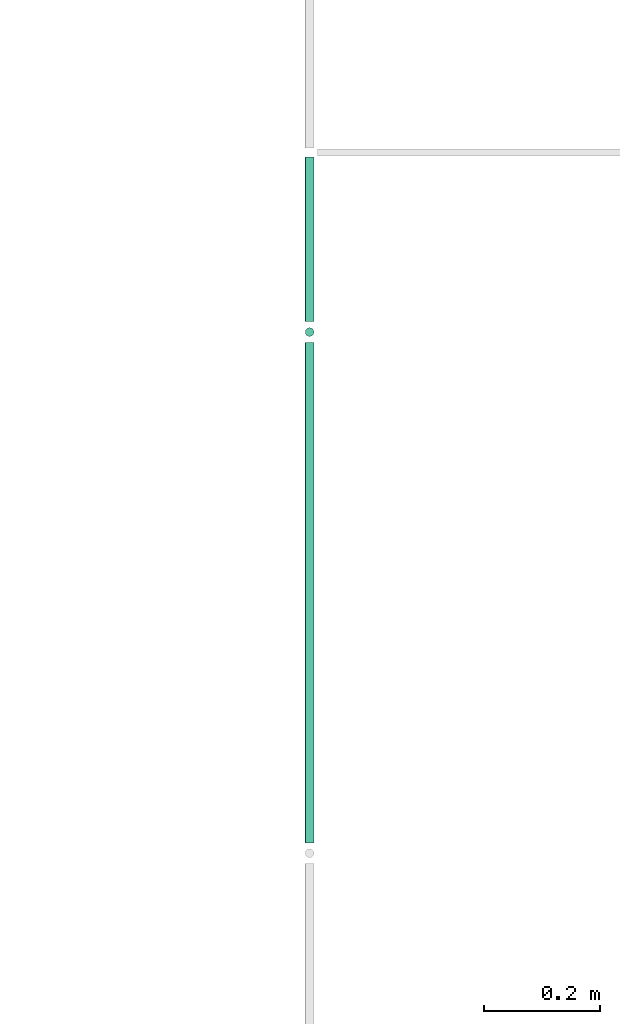
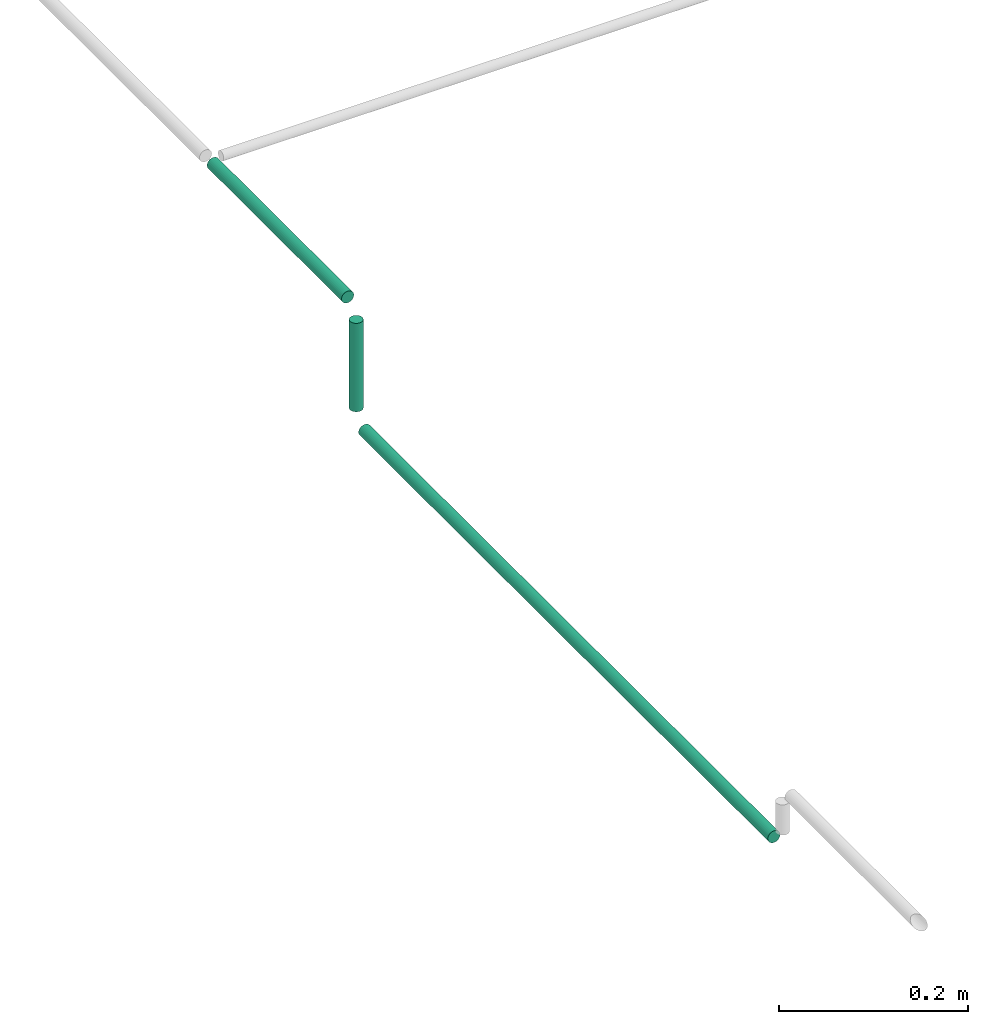
# One storey, part 43 of 65: 3 flow segments.
"""IFC2X3 building model written with IfcOpenShell, lengths in millimetres."""

import ifcopenshell
import ifcopenshell.guid

model = None  # the IFC model being written
_history = None  # IfcOwnerHistory: only IFC2X3 demands one
_inside = {}  # id of a spatial element -> (the spatial element, [elements in it])
_under = {}  # id of a project, library or spatial element -> (it, [spatial elements below it])
_declared = {}  # id of a project -> (the project, [libraries it declares])
_typed = {}  # id of a type object -> (the type object, [elements of that type])
_made_of = {}  # id of a material, layer set ... -> (it, [elements and type objects made of it])


def new_model(schema):
    """Start an empty IFC model of exactly this schema.

    Asked for "IFC4X3", IfcOpenShell would pick the latest addendum, in which some entities
    have other attributes; the version numbers below select the first issue.
    IFC2X3 requires an IfcOwnerHistory on every rooted entity: one is made here for all.
    """
    global model, _history
    if schema == "IFC4X3":
        model = ifcopenshell.file(schema_version=(4, 3, 0, 0))
    else:
        model = ifcopenshell.file(schema=schema)
    _inside.clear()
    _under.clear()
    _declared.clear()
    _typed.clear()
    _made_of.clear()
    _history = None
    if model.schema == "IFC2X3":
        org = make("IfcOrganization", Name="unknown")
        user = make(
            "IfcPersonAndOrganization",
            ThePerson=make("IfcPerson", FamilyName="unknown"),
            TheOrganization=org,
        )
        app = make(
            "IfcApplication",
            ApplicationDeveloper=org,
            Version="unknown",
            ApplicationFullName="unknown",
            ApplicationIdentifier="unknown",
        )
        _history = make(
            "IfcOwnerHistory",
            OwningUser=user,
            OwningApplication=app,
            ChangeAction="ADDED",
            CreationDate=0,
        )
    return model


def make(cls, **values):
    """One entity of the class cls with the attributes given. An attribute that is None is left unset."""
    return model.create_entity(
        cls, **{name: value for name, value in values.items() if value is not None}
    )


def entity(cls, *values):
    """Any entity or typed value of the class cls, its attributes in the order of the schema. None: left unset."""
    e = model.create_entity(cls)
    for i, value in enumerate(values):
        if value is not None:
            e[i] = value
    return e


def rooted(cls, **values):
    """An entity with a GlobalId (a new one), such as an element, a storey or a relation."""
    return make(cls, GlobalId=ifcopenshell.guid.new(), OwnerHistory=_history, **values)


def si_unit(unit_type, name, prefix=None):
    """IfcSIUnit, for example si_unit("LENGTHUNIT", "METRE", prefix="MILLI")."""
    return make("IfcSIUnit", UnitType=unit_type, Prefix=prefix, Name=name)


def converted_unit(unit_type, name, factor, base, dimensions=None, offset=None):
    """IfcConversionBasedUnit, such as the inch: factor (a typed value) times the base unit."""
    return make(
        "IfcConversionBasedUnit"
        if offset is None
        else "IfcConversionBasedUnitWithOffset",
        ConversionOffset=offset,
        Dimensions=None
        if dimensions is None
        else entity("IfcDimensionalExponents", *dimensions),
        UnitType=unit_type,
        Name=name,
        ConversionFactor=make(
            "IfcMeasureWithUnit", ValueComponent=factor, UnitComponent=base
        ),
    )


def derived_unit(unit_type, elements):
    """IfcDerivedUnit: a product of units, each with its exponent."""
    return make(
        "IfcDerivedUnit",
        Elements=[
            make("IfcDerivedUnitElement", Unit=unit, Exponent=power)
            for unit, power in elements
        ],
        UnitType=unit_type,
    )


def assignment(units):
    """IfcUnitAssignment: the units of a project."""
    return None if units is None else make("IfcUnitAssignment", Units=units)


def point(xyz):
    """IfcCartesianPoint."""
    return None if xyz is None else make("IfcCartesianPoint", Coordinates=xyz)


def direction(xyz):
    """IfcDirection."""
    return None if xyz is None else make("IfcDirection", DirectionRatios=xyz)


def frame(location, z_axis=None, x_axis=None):
    """IfcAxis2Placement3D, a coordinate frame: its origin and axes. An axis left out is left unset."""
    return make(
        "IfcAxis2Placement3D",
        Location=point(location),
        Axis=direction(z_axis),
        RefDirection=direction(x_axis),
    )


def frame_2d(location, x_axis=None):
    """IfcAxis2Placement2D, a coordinate frame in the plane: its origin and x axis."""
    return make(
        "IfcAxis2Placement2D", Location=point(location), RefDirection=direction(x_axis)
    )


def origin():
    """The frame at (0, 0, 0) with its axes left unset."""
    return frame((0.0, 0.0, 0.0))


def origin_2d_with_axis():
    """The frame at (0, 0) in the plane with the x axis (1, 0) written out."""
    return frame_2d((0.0, 0.0), x_axis=(1.0, 0.0))


def place(relative_to, where):
    """IfcLocalPlacement: puts the frame where relative to a parent placement (None: the world)."""
    return make(
        "IfcLocalPlacement", PlacementRelTo=relative_to, RelativePlacement=where
    )


def context(
    kind, dimensions, precision=None, world=None, true_north=None, identifier=None
):
    """IfcGeometricRepresentationContext, for example the 3D "Model" context."""
    return make(
        "IfcGeometricRepresentationContext",
        ContextIdentifier=identifier,
        ContextType=kind,
        CoordinateSpaceDimension=dimensions,
        Precision=precision,
        WorldCoordinateSystem=world,
        TrueNorth=true_north,
    )


def subcontext(parent, identifier, kind, view, scale=None):
    """IfcGeometricRepresentationSubContext, for example "Body" below "Model"."""
    return make(
        "IfcGeometricRepresentationSubContext",
        ContextIdentifier=identifier,
        ContextType=kind,
        ParentContext=parent,
        TargetScale=scale,
        TargetView=view,
    )


def project(units=None, contexts=None):
    """IfcProject with its units and contexts."""
    return rooted(
        "IfcProject",
        Name="project",
        RepresentationContexts=contexts,
        UnitsInContext=assignment(units),
    )


def spatial(cls, under=None, at=None, **own):
    """A site, building, storey or space (cls), placed at a placement, below another one or the project."""
    s = rooted(cls, ObjectPlacement=at, **own)
    if under is not None:
        _under.setdefault(under.id(), (under, []))[1].append(s)
    return s


def profile(cls, at=None, kind="AREA", **sizes):
    """A parametric profile (cls). Its sizes go by their IFC names, for example OverallWidth=200.0."""
    return make(cls, ProfileType=kind, Position=at, **sizes)


def circle(**sizes):
    """IfcCircleProfileDef."""
    return profile("IfcCircleProfileDef", **sizes)


def extrude(swept, where, along, depth):
    """IfcExtrudedAreaSolid: the profile swept, set in the frame where, extruded along a direction by depth."""
    return make(
        "IfcExtrudedAreaSolid",
        SweptArea=swept,
        Position=where,
        ExtrudedDirection=direction(along),
        Depth=depth,
    )


def shape(context_of_items, identifier, shape_type, items):
    """IfcShapeRepresentation: the items that make up one representation, for example the "Body"."""
    return make(
        "IfcShapeRepresentation",
        ContextOfItems=context_of_items,
        RepresentationIdentifier=identifier,
        RepresentationType=shape_type,
        Items=items,
    )


def made_of(thing, what):
    """Note that an element or type object is made of a material, layer set ...; save() writes the relation."""
    if what is not None:
        _made_of.setdefault(what.id(), (what, []))[1].append(thing)
    return thing


def type_object(cls, material=None, **own):
    """A type object (cls), such as IfcWallType, which elements share."""
    return made_of(rooted(cls, **own), material)


def element(
    cls,
    number,
    at=None,
    inside=None,
    cuts=None,
    type_object=None,
    material=None,
    context=None,
    identifier="Body",
    shape_type=None,
    held_by="IfcProductDefinitionShape",
    body=None,
    shapes=None,
    **own,
):
    """One element of the class cls, such as IfcWall. Its Tag is "e" and its number.

    at: its placement. inside: the storey or other place that contains it. cuts: it is an
    opening in that element (IfcRelVoidsElement). A single representation is given by context,
    identifier, shape_type and body (its items); several are given by shapes. held_by: the class
    of the entity that holds the representations. save() writes the other relations.
    """
    e = rooted(cls, Tag="e%d" % number, ObjectPlacement=at, **own)
    if body is not None:
        shapes = [shape(context, identifier, shape_type, body)]
    if shapes is not None:
        e.Representation = make(held_by, Representations=shapes)
    if inside is not None:
        _inside.setdefault(inside.id(), (inside, []))[1].append(e)
    if cuts is not None:
        rooted(
            "IfcRelVoidsElement", RelatingBuildingElement=cuts, RelatedOpeningElement=e
        )
    if type_object is not None:
        _typed.setdefault(type_object.id(), (type_object, []))[1].append(e)
    return made_of(e, material)


def aggregate(whole, parts):
    """IfcRelAggregates: a whole, such as a stair, and the parts it consists of."""
    return rooted("IfcRelAggregates", RelatingObject=whole, RelatedObjects=parts)


def save(model, path):
    """Write the relations noted so far, then the file.

    IfcRelAggregates (storeys below a building ...), IfcRelContainedInSpatialStructure (elements
    in a storey), IfcRelDefinesByType, IfcRelAssociatesMaterial and IfcRelDeclares: one each for
    every whole, place, type object, material and project.
    """
    for whole, parts in _under.values():
        aggregate(whole, parts)
    for where, things in _inside.values():
        rooted(
            "IfcRelContainedInSpatialStructure",
            RelatedElements=things,
            RelatingStructure=where,
        )
    for kind, things in _typed.values():
        rooted("IfcRelDefinesByType", RelatedObjects=things, RelatingType=kind)
    for what, things in _made_of.values():
        rooted("IfcRelAssociatesMaterial", RelatedObjects=things, RelatingMaterial=what)
    for by, libraries in _declared.values():
        rooted("IfcRelDeclares", RelatingContext=by, RelatedDefinitions=libraries)
    model.write(path)


model = new_model("IFC2X3")

# Units and contexts
model_context = context("Model", 3, precision=0.01, world=origin(), true_north=direction((6.12303176911189e-17, 1.0)))
body_context = subcontext(model_context, "Body", "Model", "MODEL_VIEW")
ifc_project = project(units=[si_unit("LENGTHUNIT", "METRE", prefix="MILLI"), si_unit("AREAUNIT", "SQUARE_METRE"), si_unit("VOLUMEUNIT", "CUBIC_METRE"), converted_unit("PLANEANGLEUNIT", "DEGREE", entity("IfcRatioMeasure", 0.0174532925199433), si_unit("PLANEANGLEUNIT", "RADIAN"), dimensions=[0, 0, 0, 0, 0, 0, 0]), si_unit("MASSUNIT", "GRAM", prefix="KILO"), derived_unit("MASSDENSITYUNIT", [(si_unit("MASSUNIT", "GRAM", prefix="KILO"), 1), (si_unit("LENGTHUNIT", "METRE"), -3)]), derived_unit("MOMENTOFINERTIAUNIT", [(si_unit("LENGTHUNIT", "METRE"), 4)]), si_unit("TIMEUNIT", "SECOND"), si_unit("FREQUENCYUNIT", "HERTZ"), si_unit("THERMODYNAMICTEMPERATUREUNIT", "DEGREE_CELSIUS"), derived_unit("THERMALTRANSMITTANCEUNIT", [(si_unit("MASSUNIT", "GRAM", prefix="KILO"), 1), (si_unit("THERMODYNAMICTEMPERATUREUNIT", "KELVIN"), -1), (si_unit("TIMEUNIT", "SECOND"), -3)]), derived_unit("VOLUMETRICFLOWRATEUNIT", [(si_unit("LENGTHUNIT", "METRE"), 3), (si_unit("TIMEUNIT", "SECOND"), -1)]), derived_unit("MASSFLOWRATEUNIT", [(si_unit("MASSUNIT", "GRAM", prefix="KILO"), 1), (si_unit("TIMEUNIT", "SECOND"), -1)]), derived_unit("ROTATIONALFREQUENCYUNIT", [(si_unit("TIMEUNIT", "SECOND"), -1)]), si_unit("ELECTRICCURRENTUNIT", "AMPERE"), si_unit("ELECTRICVOLTAGEUNIT", "VOLT"), si_unit("POWERUNIT", "WATT"), si_unit("FORCEUNIT", "NEWTON", prefix="KILO"), si_unit("ILLUMINANCEUNIT", "LUX"), si_unit("LUMINOUSFLUXUNIT", "LUMEN"), si_unit("LUMINOUSINTENSITYUNIT", "CANDELA"), derived_unit("USERDEFINED", [(si_unit("MASSUNIT", "GRAM", prefix="KILO"), -1), (si_unit("LENGTHUNIT", "METRE"), -2), (si_unit("TIMEUNIT", "SECOND"), 3), (si_unit("LUMINOUSFLUXUNIT", "LUMEN"), 1)]), derived_unit("LINEARVELOCITYUNIT", [(si_unit("LENGTHUNIT", "METRE"), 1), (si_unit("TIMEUNIT", "SECOND"), -1)]), si_unit("PRESSUREUNIT", "PASCAL"), derived_unit("USERDEFINED", [(si_unit("LENGTHUNIT", "METRE"), -2), (si_unit("MASSUNIT", "GRAM", prefix="KILO"), 1), (si_unit("TIMEUNIT", "SECOND"), -2)]), derived_unit("LINEARFORCEUNIT", [(si_unit("MASSUNIT", "GRAM", prefix="KILO"), 1), (si_unit("LENGTHUNIT", "METRE"), 1), (si_unit("TIMEUNIT", "SECOND"), -2), (si_unit("LENGTHUNIT", "METRE"), -1)]), derived_unit("PLANARFORCEUNIT", [(si_unit("MASSUNIT", "GRAM", prefix="KILO"), 1), (si_unit("LENGTHUNIT", "METRE"), 1), (si_unit("TIMEUNIT", "SECOND"), -2), (si_unit("LENGTHUNIT", "METRE"), -2)])], contexts=[model_context])

# Site, building, storey
site_placement = place(None, frame((0.0, -0.00077364408347762, 0.0)))
site = spatial("IfcSite", under=ifc_project, at=site_placement, CompositionType="ELEMENT")
building_placement = place(site_placement, origin())
building = spatial("IfcBuilding", under=site, at=building_placement, CompositionType="ELEMENT")
storey_placement = place(building_placement, frame((0.0, 0.0, 19800.0)))
storey = spatial("IfcBuildingStorey", under=building, at=storey_placement, CompositionType="ELEMENT", Elevation=19800.0)

# Flow segments
pipe_segment_type = type_object("IfcPipeSegmentType", PredefinedType="NOTDEFINED")
flow_segment_1_placement = place(storey_placement, frame((49085.9032995414, 10340.9048106101, 2493.0)))
element("IfcFlowSegment", 1, at=flow_segment_1_placement, inside=storey, type_object=pipe_segment_type, context=body_context, shape_type="SweptSolid", body=[
    extrude(circle(Radius=7.5, at=origin_2d_with_axis()), frame((9.09527223591419, 9.09527223591636, 0.0), z_axis=(0.0, 0.0, 1.0), x_axis=(-1.0, 0.0, 0.0)), (0.0, 0.0, 1.0), 114.000000000004),
])
flow_segment_2_placement = place(storey_placement, frame((49085.9032995414, 9468.00008284604, 2465.90472776407)))
element("IfcFlowSegment", 2, at=flow_segment_2_placement, inside=storey, type_object=pipe_segment_type, context=body_context, shape_type="SweptSolid", body=[
    extrude(circle(Radius=7.5, at=origin_2d_with_axis()), frame((9.09527223593152, 0.0, 9.09527223591419), z_axis=(0.0, 1.0, 0.0), x_axis=(1.0, 0.0, 0.0)), (0.0, 0.0, 1.0), 864.000000000005),
])
flow_segment_3_placement = place(storey_placement, frame((49085.9032995414, 10368.000082846, 2615.90472776409)))
element("IfcFlowSegment", 3, at=flow_segment_3_placement, inside=storey, type_object=pipe_segment_type, context=body_context, shape_type="SweptSolid", body=[
    extrude(circle(Radius=7.5, at=origin_2d_with_axis()), frame((9.09527223591419, 0.0, 9.09527223591419), z_axis=(0.0, 1.0, 0.0), x_axis=(1.0, 0.0, 0.0)), (0.0, 0.0, 1.0), 284.000123147607),
])

save(model, "model.ifc")
